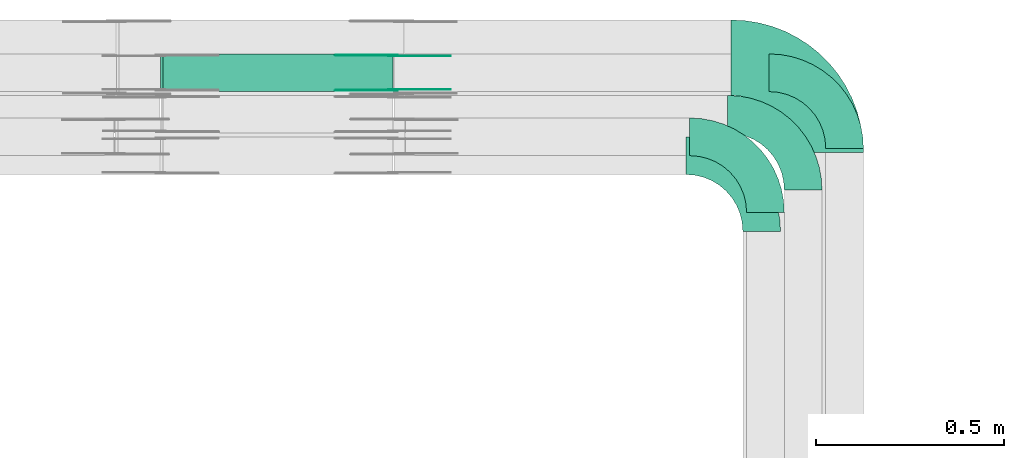
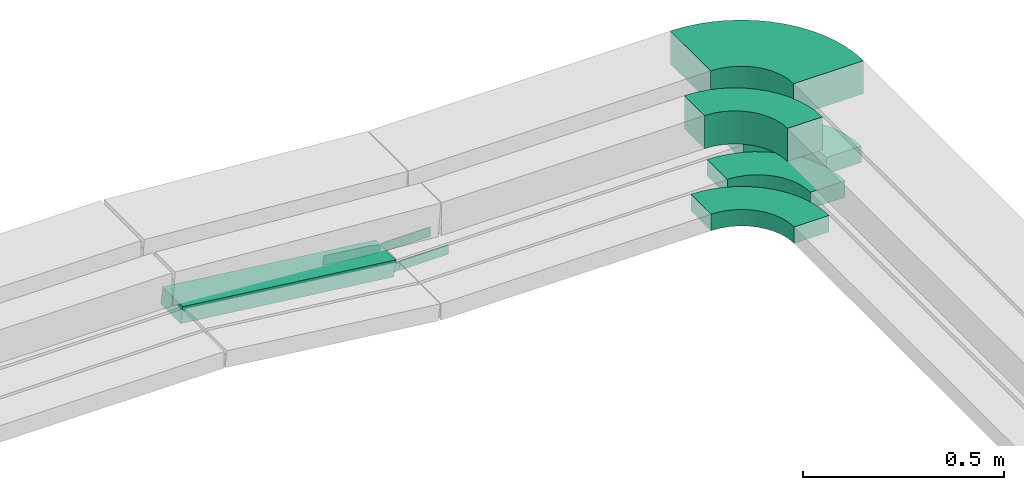
# One storey, part 24 of 25: 9 flow fittings, 1 flow segment.
"""IFC2X3 building model written with IfcOpenShell, lengths in millimetres."""

from ifc_helpers import new_model, entity, si_unit, converted_unit, derived_unit, direction, frame, frame_2d, origin, origin_2d_with_axis, place, context, subcontext, project, spatial, polyline, circle_curve, parameter, trimmed, segment, composite_curve, rectangle, outline, extrude, source, transform, mapped, material, type_object, type_shapes, element, save


model = new_model("IFC2X3")

# Units and contexts
model_context = context("Model", 3, precision=0.01, world=origin(), true_north=direction((6.12303176911189e-17, 1.0)))
body_context = subcontext(model_context, "Body", "Model", "MODEL_VIEW")
ifc_project = project(units=[si_unit("LENGTHUNIT", "METRE", prefix="MILLI"), si_unit("AREAUNIT", "SQUARE_METRE"), si_unit("VOLUMEUNIT", "CUBIC_METRE"), converted_unit("PLANEANGLEUNIT", "DEGREE", entity("IfcRatioMeasure", 0.0174532925199433), si_unit("PLANEANGLEUNIT", "RADIAN"), dimensions=[0, 0, 0, 0, 0, 0, 0]), si_unit("MASSUNIT", "GRAM", prefix="KILO"), derived_unit("MASSDENSITYUNIT", [(si_unit("MASSUNIT", "GRAM", prefix="KILO"), 1), (si_unit("LENGTHUNIT", "METRE"), -3)]), derived_unit("MOMENTOFINERTIAUNIT", [(si_unit("LENGTHUNIT", "METRE"), 4)]), si_unit("TIMEUNIT", "SECOND"), si_unit("FREQUENCYUNIT", "HERTZ"), si_unit("THERMODYNAMICTEMPERATUREUNIT", "DEGREE_CELSIUS"), derived_unit("THERMALTRANSMITTANCEUNIT", [(si_unit("MASSUNIT", "GRAM", prefix="KILO"), 1), (si_unit("THERMODYNAMICTEMPERATUREUNIT", "KELVIN"), -1), (si_unit("TIMEUNIT", "SECOND"), -3)]), derived_unit("VOLUMETRICFLOWRATEUNIT", [(si_unit("LENGTHUNIT", "METRE"), 3), (si_unit("TIMEUNIT", "SECOND"), -1)]), derived_unit("MASSFLOWRATEUNIT", [(si_unit("MASSUNIT", "GRAM", prefix="KILO"), 1), (si_unit("TIMEUNIT", "SECOND"), -1)]), derived_unit("ROTATIONALFREQUENCYUNIT", [(si_unit("TIMEUNIT", "SECOND"), -1)]), si_unit("ELECTRICCURRENTUNIT", "AMPERE"), si_unit("ELECTRICVOLTAGEUNIT", "VOLT"), si_unit("POWERUNIT", "WATT"), si_unit("FORCEUNIT", "NEWTON", prefix="KILO"), si_unit("ILLUMINANCEUNIT", "LUX"), si_unit("LUMINOUSFLUXUNIT", "LUMEN"), si_unit("LUMINOUSINTENSITYUNIT", "CANDELA"), derived_unit("USERDEFINED", [(si_unit("MASSUNIT", "GRAM", prefix="KILO"), -1), (si_unit("LENGTHUNIT", "METRE"), -2), (si_unit("TIMEUNIT", "SECOND"), 3), (si_unit("LUMINOUSFLUXUNIT", "LUMEN"), 1)]), derived_unit("LINEARVELOCITYUNIT", [(si_unit("LENGTHUNIT", "METRE"), 1), (si_unit("TIMEUNIT", "SECOND"), -1)]), si_unit("PRESSUREUNIT", "PASCAL"), derived_unit("USERDEFINED", [(si_unit("LENGTHUNIT", "METRE"), -2), (si_unit("MASSUNIT", "GRAM", prefix="KILO"), 1), (si_unit("TIMEUNIT", "SECOND"), -2)]), derived_unit("LINEARFORCEUNIT", [(si_unit("MASSUNIT", "GRAM", prefix="KILO"), 1), (si_unit("LENGTHUNIT", "METRE"), 1), (si_unit("TIMEUNIT", "SECOND"), -2), (si_unit("LENGTHUNIT", "METRE"), -1)]), derived_unit("PLANARFORCEUNIT", [(si_unit("MASSUNIT", "GRAM", prefix="KILO"), 1), (si_unit("LENGTHUNIT", "METRE"), 1), (si_unit("TIMEUNIT", "SECOND"), -2), (si_unit("LENGTHUNIT", "METRE"), -2)])], contexts=[model_context])

# Site, building, storey
site_placement = place(None, frame((0.0, -0.00077364408347762, 0.0)))
site = spatial("IfcSite", under=ifc_project, at=site_placement, CompositionType="ELEMENT")
building_placement = place(site_placement, origin())
building = spatial("IfcBuilding", under=site, at=building_placement, CompositionType="ELEMENT")
storey_placement = place(building_placement, frame((0.0, 0.0, 24000.0)))
storey = spatial("IfcBuildingStorey", under=building, at=storey_placement, CompositionType="ELEMENT", Elevation=24000.0)

# Flow segment
cable_carrier_segment_type = type_object("IfcCableCarrierSegmentType", PredefinedType="CABLETRAYSEGMENT")
flow_segment_placement = place(storey_placement, frame((63365.2790288825, 18920.0, 2973.31393320591)))
element("IfcFlowSegment", 1, at=flow_segment_placement, inside=storey, type_object=cable_carrier_segment_type, context=body_context, shape_type="SweptSolid", body=[
    extrude(rectangle(XDim=49.9999999999981, YDim=99.9999999999989, at=origin_2d_with_axis()), frame((2.92256803476798, 50.0, 96.7732542258375), z_axis=(0.993143370179474, 0.0, -0.116902721390724), x_axis=(0.116902721390724, 0.0, 0.993143370179474)), (0.0, 0.0, 1.0), 615.42339746565),
])

# Flow fittings
ifc_material_1 = material(Name="G")
cable_carrier_fitting_type_1 = type_object("IfcCableCarrierFittingType", PredefinedType="NOTDEFINED", material=ifc_material_1)
shared_shape_1 = source(origin(), body_context, "Body", "SweptSolid", [
    extrude(outline(composite_curve([segment(trimmed(circle_curve(frame_2d((-44.5901162790698, 0.0), x_axis=(1.0, 0.0)), 12.5), [parameter(90.0000000000007)], [parameter(270.0)], True, "PARAMETER"), True, "CONTINUOUS"), segment(polyline([(-44.5901162790697, -12.5), (-33.0901162790698, -12.5)]), True, "CONTINUOUS"), segment(polyline([(-33.0901162790698, -12.5), (-31.2296511627907, -14.5)]), True, "CONTINUOUS"), segment(polyline([(-31.2296511627907, -14.5), (108.90988372093, -14.5)]), True, "CONTINUOUS"), segment(polyline([(108.90988372093, -14.5), (108.90988372093, 14.5)]), True, "CONTINUOUS"), segment(polyline([(108.90988372093, 14.5), (-31.2296511627907, 14.5)]), True, "CONTINUOUS"), segment(polyline([(-31.2296511627907, 14.5), (-33.0901162790698, 12.5)]), True, "CONTINUOUS"), segment(polyline([(-33.0901162790698, 12.5), (-44.5901162790699, 12.5)]), True, "CONTINUOUS")], self_intersect=False)), frame((44.5901162790698, 0.0, 0.0), z_axis=(0.0, 0.0, -1.0), x_axis=(1.0, 0.0, 0.0)), (0.0, 0.0, -1.0), 2.0),
])
type_shapes(cable_carrier_fitting_type_1, [shared_shape_1])
flow_fitting_1_placement = place(storey_placement, frame((63982.087665502, 19015.4600000101, 2997.82677247419), z_axis=(0.0, 1.0, 0.0), x_axis=(-0.993143370179453, 0.0, 0.1169027213909)))
element("IfcFlowFitting", 2, at=flow_fitting_1_placement, inside=storey, type_object=cable_carrier_fitting_type_1, material=ifc_material_1, context=body_context, shape_type="MappedRepresentation", body=[
    mapped(shared_shape_1, transform((0.0, 0.0, 0.0), scale=1.0)),
])
cable_carrier_fitting_type_2 = type_object("IfcCableCarrierFittingType", PredefinedType="NOTDEFINED", material=ifc_material_1)
shared_shape_2 = source(origin(), body_context, "Body", "SweptSolid", [
    extrude(outline(composite_curve([segment(trimmed(circle_curve(frame_2d((-44.5901162790697, 0.0), x_axis=(1.0, 0.0)), 12.5), [parameter(90.0000000000007)], [parameter(270.0)], True, "PARAMETER"), True, "CONTINUOUS"), segment(polyline([(-44.5901162790697, -12.5), (-33.0901162790697, -12.5)]), True, "CONTINUOUS"), segment(polyline([(-33.0901162790697, -12.5), (-31.2296511627907, -14.5)]), True, "CONTINUOUS"), segment(polyline([(-31.2296511627907, -14.5), (108.90988372093, -14.5)]), True, "CONTINUOUS"), segment(polyline([(108.90988372093, -14.5), (108.90988372093, 14.5)]), True, "CONTINUOUS"), segment(polyline([(108.90988372093, 14.5), (-31.2296511627907, 14.5)]), True, "CONTINUOUS"), segment(polyline([(-31.2296511627907, 14.5), (-33.0901162790698, 12.5)]), True, "CONTINUOUS"), segment(polyline([(-33.0901162790698, 12.5), (-44.5901162790699, 12.5)]), True, "CONTINUOUS")], self_intersect=False)), frame((44.5901162790697, 0.0, 0.0)), (0.0, 0.0, 1.0), 2.0),
])
type_shapes(cable_carrier_fitting_type_2, [shared_shape_2])
flow_fitting_2_placement = place(storey_placement, frame((63982.087665502, 18924.5399999898, 2997.82677247419), z_axis=(0.0, -1.0, 0.0), x_axis=(-0.993143370179453, 0.0, 0.1169027213909)))
element("IfcFlowFitting", 3, at=flow_fitting_2_placement, inside=storey, type_object=cable_carrier_fitting_type_2, material=ifc_material_1, context=body_context, shape_type="MappedRepresentation", body=[
    mapped(shared_shape_2, transform((0.0, 0.0, 0.0), scale=1.0)),
])
cable_carrier_fitting_type_3 = type_object("IfcCableCarrierFittingType", PredefinedType="NOTDEFINED", material=ifc_material_1)
shared_shape_3 = source(origin(), body_context, "Body", "SweptSolid", [
    extrude(outline(composite_curve([segment(trimmed(circle_curve(frame_2d((-44.5901162790698, 0.0), x_axis=(1.0, 0.0)), 12.5), [parameter(90.0000000000007)], [parameter(270.0)], True, "PARAMETER"), True, "CONTINUOUS"), segment(polyline([(-44.5901162790697, -12.5), (-33.0901162790698, -12.5)]), True, "CONTINUOUS"), segment(polyline([(-33.0901162790698, -12.5), (-31.2296511627907, -14.5)]), True, "CONTINUOUS"), segment(polyline([(-31.2296511627907, -14.5), (108.90988372093, -14.5)]), True, "CONTINUOUS"), segment(polyline([(108.90988372093, -14.5), (108.90988372093, 14.5)]), True, "CONTINUOUS"), segment(polyline([(108.90988372093, 14.5), (-31.2296511627907, 14.5)]), True, "CONTINUOUS"), segment(polyline([(-31.2296511627907, 14.5), (-33.0901162790698, 12.5)]), True, "CONTINUOUS"), segment(polyline([(-33.0901162790698, 12.5), (-44.5901162790699, 12.5)]), True, "CONTINUOUS")], self_intersect=False)), frame((44.5901162790698, 0.0, 0.0), z_axis=(0.0, 0.0, -1.0), x_axis=(1.0, 0.0, 0.0)), (0.0, 0.0, -1.0), 2.0),
])
type_shapes(cable_carrier_fitting_type_3, [shared_shape_3])
flow_fitting_3_placement = place(storey_placement, frame((63982.087665502, 18926.5399999898, 2997.82677247419), z_axis=(0.0, -1.0, 0.0), x_axis=(1.0, 0.0, 0.0)))
element("IfcFlowFitting", 4, at=flow_fitting_3_placement, inside=storey, type_object=cable_carrier_fitting_type_3, material=ifc_material_1, context=body_context, shape_type="MappedRepresentation", body=[
    mapped(shared_shape_3, transform((0.0, 0.0, 0.0), scale=1.0)),
])
cable_carrier_fitting_type_4 = type_object("IfcCableCarrierFittingType", PredefinedType="NOTDEFINED", material=ifc_material_1)
shared_shape_4 = source(origin(), body_context, "Body", "SweptSolid", [
    extrude(outline(composite_curve([segment(trimmed(circle_curve(frame_2d((-44.5901162790697, 0.0), x_axis=(1.0, 0.0)), 12.5), [parameter(90.0000000000007)], [parameter(270.0)], True, "PARAMETER"), True, "CONTINUOUS"), segment(polyline([(-44.5901162790697, -12.5), (-33.0901162790697, -12.5)]), True, "CONTINUOUS"), segment(polyline([(-33.0901162790697, -12.5), (-31.2296511627907, -14.5)]), True, "CONTINUOUS"), segment(polyline([(-31.2296511627907, -14.5), (108.90988372093, -14.5)]), True, "CONTINUOUS"), segment(polyline([(108.90988372093, -14.5), (108.90988372093, 14.5)]), True, "CONTINUOUS"), segment(polyline([(108.90988372093, 14.5), (-31.2296511627907, 14.5)]), True, "CONTINUOUS"), segment(polyline([(-31.2296511627907, 14.5), (-33.0901162790698, 12.5)]), True, "CONTINUOUS"), segment(polyline([(-33.0901162790698, 12.5), (-44.5901162790699, 12.5)]), True, "CONTINUOUS")], self_intersect=False)), frame((44.5901162790697, 0.0, 0.0)), (0.0, 0.0, 1.0), 2.0),
])
type_shapes(cable_carrier_fitting_type_4, [shared_shape_4])
flow_fitting_4_placement = place(storey_placement, frame((63982.087665502, 19013.4600000101, 2997.82677247419), z_axis=(0.0, 1.0, 0.0), x_axis=(1.0, 0.0, 0.0)))
element("IfcFlowFitting", 5, at=flow_fitting_4_placement, inside=storey, type_object=cable_carrier_fitting_type_4, material=ifc_material_1, context=body_context, shape_type="MappedRepresentation", body=[
    mapped(shared_shape_4, transform((0.0, 0.0, 0.0), scale=1.0)),
])
ifc_material_2 = material()
cable_carrier_fitting_type_5 = type_object("IfcCableCarrierFittingType", Name="470_DKC_S5_Variable Angle Elbow 0-45:-", PredefinedType="NOTDEFINED", material=ifc_material_2)
shared_shape_5 = source(origin(), body_context, "Body", "SweptSolid", [
    extrude(outline(composite_curve([segment(polyline([(-125.750000000001, -225.25), (-124.749999999999, -225.25)]), True, "CONTINUOUS"), segment(trimmed(circle_curve(frame_2d((-124.75, 124.75), x_axis=(0.0, -1.0)), 350.0), [parameter(0.0)], [parameter(90.0000000000001)], True, "PARAMETER"), True, "CONTINUOUS"), segment(polyline([(225.25, 124.75), (225.25, 125.749999999999)]), True, "CONTINUOUS"), segment(polyline([(225.25, 125.749999999999), (25.25, 125.750000000001)]), True, "CONTINUOUS"), segment(polyline([(25.25, 125.750000000001), (25.25, 124.75)]), True, "CONTINUOUS"), segment(trimmed(circle_curve(frame_2d((-124.75, 124.75), x_axis=(0.0, -1.0)), 150.0), [parameter(0.0)], [parameter(90.0000000000001)], True, "PARAMETER"), False, "CONTINUOUS"), segment(polyline([(-124.749999999999, -25.2500000000003), (-125.750000000001, -25.2500000000003)]), True, "CONTINUOUS"), segment(polyline([(-125.750000000001, -25.2500000000003), (-125.750000000001, -225.25)]), True, "CONTINUOUS")], self_intersect=False)), frame((-125.249999999991, 125.249999999992, -50.0)), (0.0, 0.0, 1.0), 100.0),
])
type_shapes(cable_carrier_fitting_type_5, [shared_shape_5])
flow_fitting_5_placement = place(storey_placement, frame((65130.0810452562, 19010.0, 3237.82677247422), z_axis=(0.0, 0.0, 1.0), x_axis=(0.0, 1.0, 0.0)))
element("IfcFlowFitting", 6, at=flow_fitting_5_placement, inside=storey, type_object=cable_carrier_fitting_type_5, material=ifc_material_2, Name="470_DKC_S5_Variable Angle Elbow 0-45:-", ObjectType="470_DKC_S5_Variable Angle Elbow 0-45:-", context=body_context, shape_type="MappedRepresentation", body=[
    mapped(shared_shape_5, transform((0.0, 0.0, 0.0), scale=1.0)),
])
cable_carrier_fitting_type_6 = type_object("IfcCableCarrierFittingType", Name="470_DKC_S5_Variable Angle Elbow 0-45:-", PredefinedType="NOTDEFINED", material=ifc_material_2)
shared_shape_6 = source(origin(), body_context, "Body", "SweptSolid", [
    extrude(outline(composite_curve([segment(polyline([(-100.749999999999, -150.250000000001), (-99.7499999999981, -150.250000000001)]), True, "CONTINUOUS"), segment(trimmed(circle_curve(frame_2d((-99.7500000000006, 99.7499999999987), x_axis=(0.0, -1.0)), 250.0), [parameter(0.0)], [parameter(90.0000000000001)], True, "PARAMETER"), True, "CONTINUOUS"), segment(polyline([(150.249999999999, 99.7500000000013), (150.249999999999, 100.750000000001)]), True, "CONTINUOUS"), segment(polyline([(150.249999999999, 100.750000000001), (50.2499999999992, 100.750000000001)]), True, "CONTINUOUS"), segment(polyline([(50.2499999999992, 100.750000000001), (50.2499999999992, 99.7500000000002)]), True, "CONTINUOUS"), segment(trimmed(circle_curve(frame_2d((-99.7500000000006, 99.7499999999987), x_axis=(0.0, -1.0)), 150.0), [parameter(0.0)], [parameter(90.0000000000001)], True, "PARAMETER"), False, "CONTINUOUS"), segment(polyline([(-99.7499999999989, -50.2500000000011), (-100.75, -50.2500000000011)]), True, "CONTINUOUS"), segment(polyline([(-100.75, -50.2500000000011), (-100.749999999999, -150.250000000001)]), True, "CONTINUOUS")], self_intersect=False)), frame((-100.249999999991, 100.249999999992, -50.0)), (0.0, 0.0, 1.0), 100.0),
])
type_shapes(cable_carrier_fitting_type_6, [shared_shape_6])
flow_fitting_6_placement = place(storey_placement, frame((64970.0810452563, 18800.0, 3237.82677247422), z_axis=(0.0, 0.0, 1.0), x_axis=(0.0, 1.0, 0.0)))
element("IfcFlowFitting", 7, at=flow_fitting_6_placement, inside=storey, type_object=cable_carrier_fitting_type_6, material=ifc_material_2, Name="470_DKC_S5_Variable Angle Elbow 0-45:-", ObjectType="470_DKC_S5_Variable Angle Elbow 0-45:-", context=body_context, shape_type="MappedRepresentation", body=[
    mapped(shared_shape_6, transform((0.0, 0.0, 0.0), scale=1.0)),
])
cable_carrier_fitting_type_7 = type_object("IfcCableCarrierFittingType", Name="470_DKC_S5_Variable Angle Elbow 0-45:-", PredefinedType="NOTDEFINED", material=ifc_material_2)
shared_shape_7 = source(origin(), body_context, "Body", "SweptSolid", [
    extrude(outline(composite_curve([segment(polyline([(-100.750000000001, -150.25), (-99.7499999999994, -150.25)]), True, "CONTINUOUS"), segment(trimmed(circle_curve(frame_2d((-99.7499999999997, 99.7499999999995), x_axis=(0.0, -1.0)), 250.0), [parameter(0.0)], [parameter(90.0000000000001)], True, "PARAMETER"), True, "CONTINUOUS"), segment(polyline([(150.25, 99.75), (150.25, 100.749999999999)]), True, "CONTINUOUS"), segment(polyline([(150.25, 100.749999999999), (50.25, 100.75)]), True, "CONTINUOUS"), segment(polyline([(50.25, 100.75), (50.25, 99.7499999999998)]), True, "CONTINUOUS"), segment(trimmed(circle_curve(frame_2d((-99.7499999999997, 99.7499999999995), x_axis=(0.0, -1.0)), 150.0), [parameter(0.0)], [parameter(90.0000000000001)], True, "PARAMETER"), False, "CONTINUOUS"), segment(polyline([(-99.7499999999994, -50.2500000000003), (-100.750000000001, -50.2500000000003)]), True, "CONTINUOUS"), segment(polyline([(-100.750000000001, -50.2500000000003), (-100.750000000001, -150.25)]), True, "CONTINUOUS")], self_intersect=False)), frame((-100.249999999991, 100.249999999992, -25.0)), (0.0, 0.0, 1.0), 49.9999999999997),
])
type_shapes(cable_carrier_fitting_type_7, [shared_shape_7])
for number, where, z_axis, x_axis, name in (
    (8, (65180.0810452562, 18970.0, 2997.82677247422), (0.0, 0.0, 1.0), (0.0, 1.0, 0.0), "470_DKC_S5_Variable Angle Elbow 0-45:-"),
    (9, (65070.0810452562, 18860.0, 2997.82677247422), (0.0, 0.0, 1.0), (0.0, 1.0, 0.0), "470_DKC_S5_Variable Angle Elbow 0-45:-"),
    (10, (64960.0810452562, 18750.0, 2997.82677247422), (0.0, 0.0, 1.0), (0.0, 1.0, 0.0), "470_DKC_S5_Variable Angle Elbow 0-45:-"),
):
    element("IfcFlowFitting", number, at=place(storey_placement, frame(where, z_axis=z_axis, x_axis=x_axis)), inside=storey, type_object=cable_carrier_fitting_type_7, material=ifc_material_2, Name=name, ObjectType="470_DKC_S5_Variable Angle Elbow 0-45:-", context=body_context, shape_type="MappedRepresentation", body=[
        mapped(shared_shape_7, transform((0.0, 0.0, 0.0), scale=1.0)),
    ])

save(model, "model.ifc")
